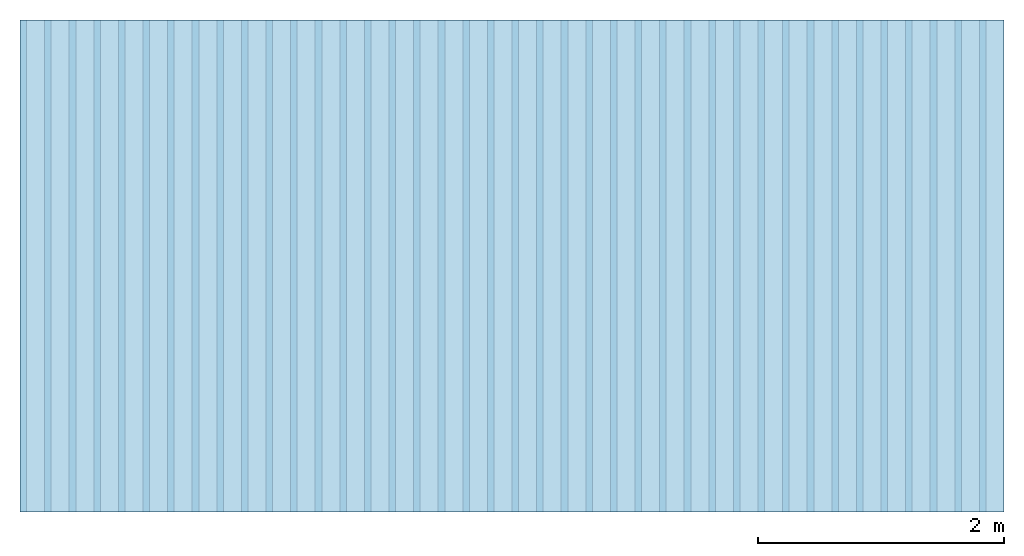
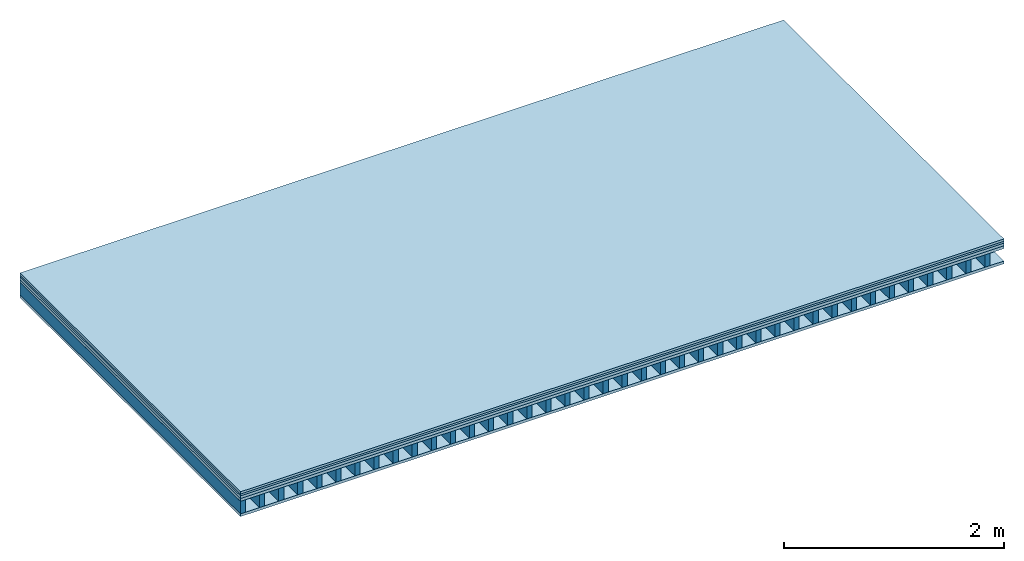
# One storey: 5 plates, 1 member, 1 element without a shape of its own.
"""IFC4 building model written with IfcOpenShell, lengths in metres."""

from ifc_helpers import new_model, si_unit, derived_unit, direction, frame, frame_2d, origin, origin_with_axes, place, context, project, spatial, rectangle, extrude, material, layer, layer_set, type_object, element, aggregate, save


model = new_model("IFC4")

# Units and contexts
plan_context = context("Plan", 3, precision=1e-05, world=origin(), true_north=direction((0.0, 1.0)))
model_context = context("Model", 3, precision=1e-05, world=origin(), true_north=direction((0.0, 1.0)))
ifc_project = project(units=[si_unit("LENGTHUNIT", "METRE"), derived_unit("SOUNDPRESSUREUNIT", [(si_unit("PRESSUREUNIT", "PASCAL", prefix="MICRO"), 0)]), si_unit("ENERGYUNIT", "JOULE", prefix="MEGA"), si_unit("MASSUNIT", "GRAM", prefix="KILO"), derived_unit("THERMALTRANSMITTANCEUNIT", [(si_unit("POWERUNIT", "WATT"), 1), (si_unit("AREAUNIT", "SQUARE_METRE"), -1), (si_unit("THERMODYNAMICTEMPERATUREUNIT", "KELVIN"), -1)]), derived_unit("AREADENSITYUNIT", [(si_unit("MASSUNIT", "GRAM", prefix="KILO"), 1), (si_unit("AREAUNIT", "SQUARE_METRE"), -1)]), derived_unit("USERDEFINED", [(si_unit("ENERGYUNIT", "JOULE", prefix="MEGA"), 1), (si_unit("AREAUNIT", "SQUARE_METRE"), -1)])], contexts=[plan_context, model_context])

# Site, building, storey
site = spatial("IfcSite", under=ifc_project)
building_placement = place(None, origin())
building = spatial("IfcBuilding", under=site, at=building_placement)
storey_placement = place(building_placement, origin())
storey = spatial("IfcBuildingStorey", under=building, at=storey_placement)

# Slab, member, plates
ifc_material_1 = material(Category="03.007")
ifc_layer_1 = layer(ifc_material_1, 0.025, Name="On-material")
ifc_material_2 = material(Name="20mm", Category="10.009")
ifc_layer_2 = layer(ifc_material_2, 0.02, Name="Impact sound insulation")
ifc_material_3 = material(Name="with broken")
ifc_layer_3 = layer(ifc_material_3, 0.03, Name="on Supporting structure")
ifc_material_4 = material(Name="box-element sheathing above")
ifc_layer_4 = layer(ifc_material_4, 0.031, Name="Sub-floor")
ifc_layer_5 = layer(None, 0.138, Name="Supporting structure")
ifc_material_5 = material(Name="box-element sheathing below")
ifc_layer_6 = layer(ifc_material_5, 0.031, Name="Lower layer 1")
ifc_layer_set = layer_set([ifc_layer_1, ifc_layer_2, ifc_layer_3, ifc_layer_4, ifc_layer_5, ifc_layer_6])
slab_type = type_object("IfcSlabType", Name="A0027", PredefinedType="NOTDEFINED", material=ifc_layer_set)
slab_placement = place(None, frame((0.0, 0.0, 0.0), z_axis=(0.0, 0.0, -1.0), x_axis=(1.0, 0.0, 0.0)))
slab = element("IfcSlab", 1, at=slab_placement, inside=storey, type_object=slab_type, material=ifc_layer_set, Name="Slab #1")
ifc_material_6 = material(Name="box-element LKE")
member_placement = place(slab_placement, origin())
member = element("IfcMember", 2, at=member_placement, material=ifc_material_6, Name="Supporting structure", context=plan_context, shape_type="SweptSolid", body=[
    extrude(rectangle(XDim=0.054, YDim=0.138, at=frame_2d((0.027, 0.069), x_axis=(1.0, 0.0))), frame((0.0, 4.0, 0.106), z_axis=(0.0, -1.0, 0.0), x_axis=(1.0, 0.0, 0.0)), (0.0, 0.0, 1.0), 4.0),
    extrude(rectangle(XDim=0.054, YDim=0.138, at=frame_2d((0.027, 0.069), x_axis=(1.0, 0.0))), frame((0.2, 4.0, 0.106), z_axis=(0.0, -1.0, 0.0), x_axis=(1.0, 0.0, 0.0)), (0.0, 0.0, 1.0), 4.0),
    extrude(rectangle(XDim=0.054, YDim=0.138, at=frame_2d((0.027, 0.069), x_axis=(1.0, 0.0))), frame((0.4, 4.0, 0.106), z_axis=(0.0, -1.0, 0.0), x_axis=(1.0, 0.0, 0.0)), (0.0, 0.0, 1.0), 4.0),
    extrude(rectangle(XDim=0.054, YDim=0.138, at=frame_2d((0.027, 0.069), x_axis=(1.0, 0.0))), frame((0.6, 4.0, 0.106), z_axis=(0.0, -1.0, 0.0), x_axis=(1.0, 0.0, 0.0)), (0.0, 0.0, 1.0), 4.0),
    extrude(rectangle(XDim=0.054, YDim=0.138, at=frame_2d((0.027, 0.069), x_axis=(1.0, 0.0))), frame((0.8, 4.0, 0.106), z_axis=(0.0, -1.0, 0.0), x_axis=(1.0, 0.0, 0.0)), (0.0, 0.0, 1.0), 4.0),
    extrude(rectangle(XDim=0.054, YDim=0.138, at=frame_2d((0.027, 0.069), x_axis=(1.0, 0.0))), frame((1.0, 4.0, 0.106), z_axis=(0.0, -1.0, 0.0), x_axis=(1.0, 0.0, 0.0)), (0.0, 0.0, 1.0), 4.0),
    extrude(rectangle(XDim=0.054, YDim=0.138, at=frame_2d((0.027, 0.069), x_axis=(1.0, 0.0))), frame((1.2, 4.0, 0.106), z_axis=(0.0, -1.0, 0.0), x_axis=(1.0, 0.0, 0.0)), (0.0, 0.0, 1.0), 4.0),
    extrude(rectangle(XDim=0.054, YDim=0.138, at=frame_2d((0.027, 0.069), x_axis=(1.0, 0.0))), frame((1.4, 4.0, 0.106), z_axis=(0.0, -1.0, 0.0), x_axis=(1.0, 0.0, 0.0)), (0.0, 0.0, 1.0), 4.0),
    extrude(rectangle(XDim=0.054, YDim=0.138, at=frame_2d((0.027, 0.069), x_axis=(1.0, 0.0))), frame((1.6, 4.0, 0.106), z_axis=(0.0, -1.0, 0.0), x_axis=(1.0, 0.0, 0.0)), (0.0, 0.0, 1.0), 4.0),
    extrude(rectangle(XDim=0.054, YDim=0.138, at=frame_2d((0.027, 0.069), x_axis=(1.0, 0.0))), frame((1.8, 4.0, 0.106), z_axis=(0.0, -1.0, 0.0), x_axis=(1.0, 0.0, 0.0)), (0.0, 0.0, 1.0), 4.0),
    extrude(rectangle(XDim=0.054, YDim=0.138, at=frame_2d((0.027, 0.069), x_axis=(1.0, 0.0))), frame((2.0, 4.0, 0.106), z_axis=(0.0, -1.0, 0.0), x_axis=(1.0, 0.0, 0.0)), (0.0, 0.0, 1.0), 4.0),
    extrude(rectangle(XDim=0.054, YDim=0.138, at=frame_2d((0.027, 0.069), x_axis=(1.0, 0.0))), frame((2.2, 4.0, 0.106), z_axis=(0.0, -1.0, 0.0), x_axis=(1.0, 0.0, 0.0)), (0.0, 0.0, 1.0), 4.0),
    extrude(rectangle(XDim=0.054, YDim=0.138, at=frame_2d((0.027, 0.069), x_axis=(1.0, 0.0))), frame((2.4, 4.0, 0.106), z_axis=(0.0, -1.0, 0.0), x_axis=(1.0, 0.0, 0.0)), (0.0, 0.0, 1.0), 4.0),
    extrude(rectangle(XDim=0.054, YDim=0.138, at=frame_2d((0.027, 0.069), x_axis=(1.0, 0.0))), frame((2.6, 4.0, 0.106), z_axis=(0.0, -1.0, 0.0), x_axis=(1.0, 0.0, 0.0)), (0.0, 0.0, 1.0), 4.0),
    extrude(rectangle(XDim=0.054, YDim=0.138, at=frame_2d((0.027, 0.069), x_axis=(1.0, 0.0))), frame((2.8, 4.0, 0.106), z_axis=(0.0, -1.0, 0.0), x_axis=(1.0, 0.0, 0.0)), (0.0, 0.0, 1.0), 4.0),
    extrude(rectangle(XDim=0.054, YDim=0.138, at=frame_2d((0.027, 0.069), x_axis=(1.0, 0.0))), frame((3.0, 4.0, 0.106), z_axis=(0.0, -1.0, 0.0), x_axis=(1.0, 0.0, 0.0)), (0.0, 0.0, 1.0), 4.0),
    extrude(rectangle(XDim=0.054, YDim=0.138, at=frame_2d((0.027, 0.069), x_axis=(1.0, 0.0))), frame((3.2, 4.0, 0.106), z_axis=(0.0, -1.0, 0.0), x_axis=(1.0, 0.0, 0.0)), (0.0, 0.0, 1.0), 4.0),
    extrude(rectangle(XDim=0.054, YDim=0.138, at=frame_2d((0.027, 0.069), x_axis=(1.0, 0.0))), frame((3.4, 4.0, 0.106), z_axis=(0.0, -1.0, 0.0), x_axis=(1.0, 0.0, 0.0)), (0.0, 0.0, 1.0), 4.0),
    extrude(rectangle(XDim=0.054, YDim=0.138, at=frame_2d((0.027, 0.069), x_axis=(1.0, 0.0))), frame((3.6, 4.0, 0.106), z_axis=(0.0, -1.0, 0.0), x_axis=(1.0, 0.0, 0.0)), (0.0, 0.0, 1.0), 4.0),
    extrude(rectangle(XDim=0.054, YDim=0.138, at=frame_2d((0.027, 0.069), x_axis=(1.0, 0.0))), frame((3.8, 4.0, 0.106), z_axis=(0.0, -1.0, 0.0), x_axis=(1.0, 0.0, 0.0)), (0.0, 0.0, 1.0), 4.0),
    extrude(rectangle(XDim=0.054, YDim=0.138, at=frame_2d((0.027, 0.069), x_axis=(1.0, 0.0))), frame((4.0, 4.0, 0.106), z_axis=(0.0, -1.0, 0.0), x_axis=(1.0, 0.0, 0.0)), (0.0, 0.0, 1.0), 4.0),
    extrude(rectangle(XDim=0.054, YDim=0.138, at=frame_2d((0.027, 0.069), x_axis=(1.0, 0.0))), frame((4.2, 4.0, 0.106), z_axis=(0.0, -1.0, 0.0), x_axis=(1.0, 0.0, 0.0)), (0.0, 0.0, 1.0), 4.0),
    extrude(rectangle(XDim=0.054, YDim=0.138, at=frame_2d((0.027, 0.069), x_axis=(1.0, 0.0))), frame((4.4, 4.0, 0.106), z_axis=(0.0, -1.0, 0.0), x_axis=(1.0, 0.0, 0.0)), (0.0, 0.0, 1.0), 4.0),
    extrude(rectangle(XDim=0.054, YDim=0.138, at=frame_2d((0.027, 0.069), x_axis=(1.0, 0.0))), frame((4.6, 4.0, 0.106), z_axis=(0.0, -1.0, 0.0), x_axis=(1.0, 0.0, 0.0)), (0.0, 0.0, 1.0), 4.0),
    extrude(rectangle(XDim=0.054, YDim=0.138, at=frame_2d((0.027, 0.069), x_axis=(1.0, 0.0))), frame((4.8, 4.0, 0.106), z_axis=(0.0, -1.0, 0.0), x_axis=(1.0, 0.0, 0.0)), (0.0, 0.0, 1.0), 4.0),
    extrude(rectangle(XDim=0.054, YDim=0.138, at=frame_2d((0.027, 0.069), x_axis=(1.0, 0.0))), frame((5.0, 4.0, 0.106), z_axis=(0.0, -1.0, 0.0), x_axis=(1.0, 0.0, 0.0)), (0.0, 0.0, 1.0), 4.0),
    extrude(rectangle(XDim=0.054, YDim=0.138, at=frame_2d((0.027, 0.069), x_axis=(1.0, 0.0))), frame((5.2, 4.0, 0.106), z_axis=(0.0, -1.0, 0.0), x_axis=(1.0, 0.0, 0.0)), (0.0, 0.0, 1.0), 4.0),
    extrude(rectangle(XDim=0.054, YDim=0.138, at=frame_2d((0.027, 0.069), x_axis=(1.0, 0.0))), frame((5.4, 4.0, 0.106), z_axis=(0.0, -1.0, 0.0), x_axis=(1.0, 0.0, 0.0)), (0.0, 0.0, 1.0), 4.0),
    extrude(rectangle(XDim=0.054, YDim=0.138, at=frame_2d((0.027, 0.069), x_axis=(1.0, 0.0))), frame((5.6, 4.0, 0.106), z_axis=(0.0, -1.0, 0.0), x_axis=(1.0, 0.0, 0.0)), (0.0, 0.0, 1.0), 4.0),
    extrude(rectangle(XDim=0.054, YDim=0.138, at=frame_2d((0.027, 0.069), x_axis=(1.0, 0.0))), frame((5.8, 4.0, 0.106), z_axis=(0.0, -1.0, 0.0), x_axis=(1.0, 0.0, 0.0)), (0.0, 0.0, 1.0), 4.0),
    extrude(rectangle(XDim=0.054, YDim=0.138, at=frame_2d((0.027, 0.069), x_axis=(1.0, 0.0))), frame((6.0, 4.0, 0.106), z_axis=(0.0, -1.0, 0.0), x_axis=(1.0, 0.0, 0.0)), (0.0, 0.0, 1.0), 4.0),
    extrude(rectangle(XDim=0.054, YDim=0.138, at=frame_2d((0.027, 0.069), x_axis=(1.0, 0.0))), frame((6.2, 4.0, 0.106), z_axis=(0.0, -1.0, 0.0), x_axis=(1.0, 0.0, 0.0)), (0.0, 0.0, 1.0), 4.0),
    extrude(rectangle(XDim=0.054, YDim=0.138, at=frame_2d((0.027, 0.069), x_axis=(1.0, 0.0))), frame((6.4, 4.0, 0.106), z_axis=(0.0, -1.0, 0.0), x_axis=(1.0, 0.0, 0.0)), (0.0, 0.0, 1.0), 4.0),
    extrude(rectangle(XDim=0.054, YDim=0.138, at=frame_2d((0.027, 0.069), x_axis=(1.0, 0.0))), frame((6.6, 4.0, 0.106), z_axis=(0.0, -1.0, 0.0), x_axis=(1.0, 0.0, 0.0)), (0.0, 0.0, 1.0), 4.0),
    extrude(rectangle(XDim=0.054, YDim=0.138, at=frame_2d((0.027, 0.069), x_axis=(1.0, 0.0))), frame((6.8, 4.0, 0.106), z_axis=(0.0, -1.0, 0.0), x_axis=(1.0, 0.0, 0.0)), (0.0, 0.0, 1.0), 4.0),
    extrude(rectangle(XDim=0.054, YDim=0.138, at=frame_2d((0.027, 0.069), x_axis=(1.0, 0.0))), frame((7.0, 4.0, 0.106), z_axis=(0.0, -1.0, 0.0), x_axis=(1.0, 0.0, 0.0)), (0.0, 0.0, 1.0), 4.0),
    extrude(rectangle(XDim=0.054, YDim=0.138, at=frame_2d((0.027, 0.069), x_axis=(1.0, 0.0))), frame((7.2, 4.0, 0.106), z_axis=(0.0, -1.0, 0.0), x_axis=(1.0, 0.0, 0.0)), (0.0, 0.0, 1.0), 4.0),
    extrude(rectangle(XDim=0.054, YDim=0.138, at=frame_2d((0.027, 0.069), x_axis=(1.0, 0.0))), frame((7.4, 4.0, 0.106), z_axis=(0.0, -1.0, 0.0), x_axis=(1.0, 0.0, 0.0)), (0.0, 0.0, 1.0), 4.0),
    extrude(rectangle(XDim=0.054, YDim=0.138, at=frame_2d((0.027, 0.069), x_axis=(1.0, 0.0))), frame((7.6, 4.0, 0.106), z_axis=(0.0, -1.0, 0.0), x_axis=(1.0, 0.0, 0.0)), (0.0, 0.0, 1.0), 4.0),
    extrude(rectangle(XDim=0.054, YDim=0.138, at=frame_2d((0.027, 0.069), x_axis=(1.0, 0.0))), frame((7.8, 4.0, 0.106), z_axis=(0.0, -1.0, 0.0), x_axis=(1.0, 0.0, 0.0)), (0.0, 0.0, 1.0), 4.0),
])
plate_1_placement = place(slab_placement, origin())
plate_1 = element("IfcPlate", 3, at=plate_1_placement, material=ifc_material_1, Name="On-material", context=plan_context, shape_type="SweptSolid", body=[
    extrude(rectangle(XDim=8.0, YDim=4.0, at=frame_2d((4.0, 2.0), x_axis=(1.0, 0.0))), origin_with_axes(), (0.0, 0.0, 1.0), 0.025),
])
plate_2_placement = place(slab_placement, origin())
plate_2 = element("IfcPlate", 4, at=plate_2_placement, material=ifc_material_2, Name="Impact sound insulation", context=plan_context, shape_type="SweptSolid", body=[
    extrude(rectangle(XDim=8.0, YDim=4.0, at=frame_2d((4.0, 2.0), x_axis=(1.0, 0.0))), frame((0.0, 0.0, 0.025), z_axis=(0.0, 0.0, 1.0), x_axis=(1.0, 0.0, 0.0)), (0.0, 0.0, 1.0), 0.02),
])
plate_3_placement = place(slab_placement, origin())
plate_3 = element("IfcPlate", 5, at=plate_3_placement, material=ifc_material_3, Name="on Supporting structure", context=plan_context, shape_type="SweptSolid", body=[
    extrude(rectangle(XDim=8.0, YDim=4.0, at=frame_2d((4.0, 2.0), x_axis=(1.0, 0.0))), frame((0.0, 0.0, 0.045), z_axis=(0.0, 0.0, 1.0), x_axis=(1.0, 0.0, 0.0)), (0.0, 0.0, 1.0), 0.03),
])
plate_4_placement = place(slab_placement, origin())
plate_4 = element("IfcPlate", 6, at=plate_4_placement, material=ifc_material_4, Name="Sub-floor", context=plan_context, shape_type="SweptSolid", body=[
    extrude(rectangle(XDim=8.0, YDim=4.0, at=frame_2d((4.0, 2.0), x_axis=(1.0, 0.0))), frame((0.0, 0.0, 0.075), z_axis=(0.0, 0.0, 1.0), x_axis=(1.0, 0.0, 0.0)), (0.0, 0.0, 1.0), 0.031),
])
plate_5_placement = place(slab_placement, origin())
plate_5 = element("IfcPlate", 7, at=plate_5_placement, material=ifc_material_5, Name="Lower layer 1", context=plan_context, shape_type="SweptSolid", body=[
    extrude(rectangle(XDim=8.0, YDim=4.0, at=frame_2d((4.0, 2.0), x_axis=(1.0, 0.0))), frame((0.0, 0.0, 0.244), z_axis=(0.0, 0.0, 1.0), x_axis=(1.0, 0.0, 0.0)), (0.0, 0.0, 1.0), 0.031),
])
aggregate(slab, [plate_1, plate_2, plate_3, plate_4, member, plate_5])

save(model, "model.ifc")
